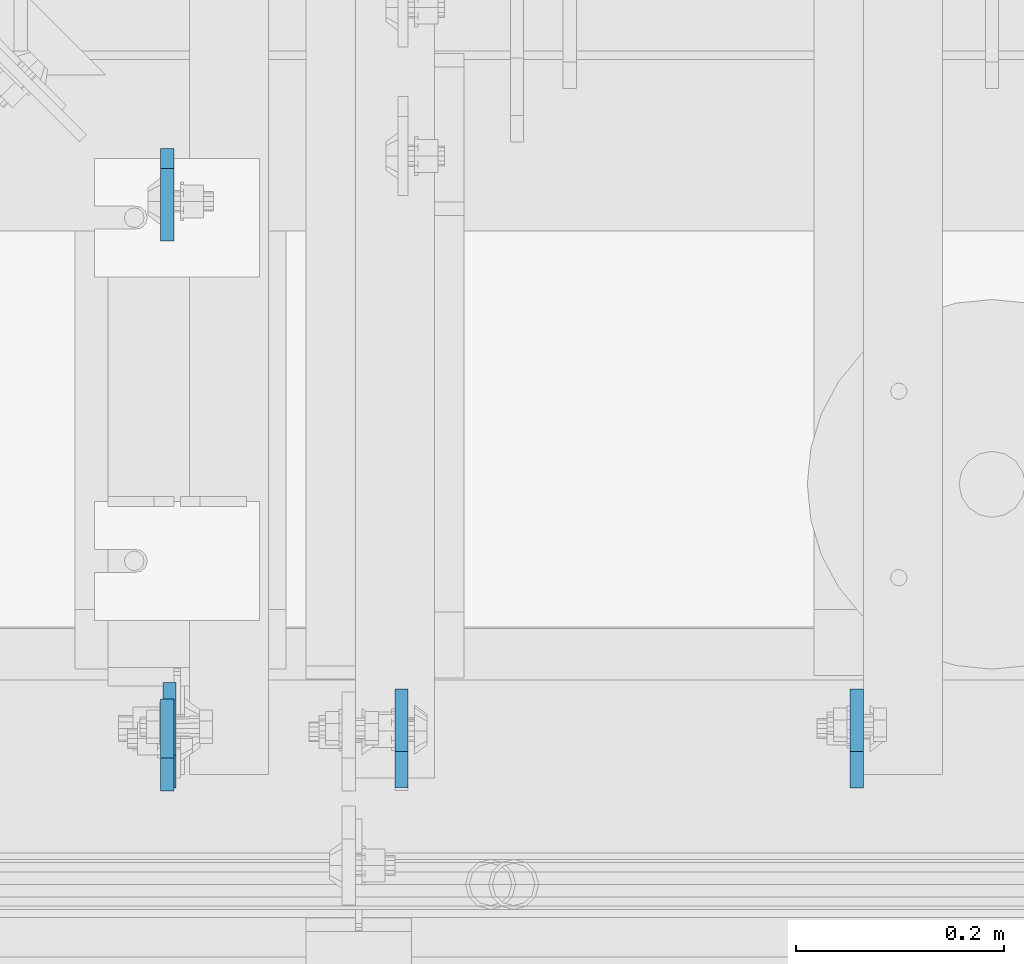
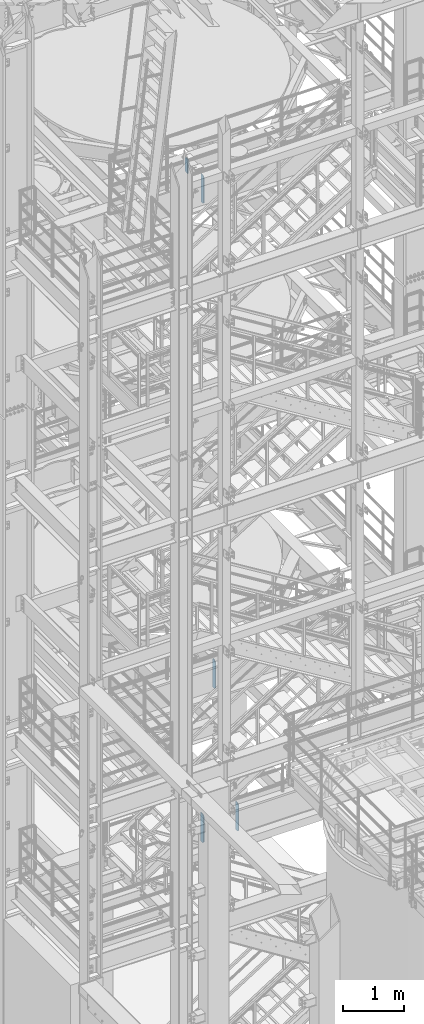
# One storey, part 1495 of 1876: 5 plates, 4 elements without a shape of their own.
"""IFC2X3 building model written with IfcOpenShell, lengths in millimetres."""

from ifc_helpers import new_model, si_unit, frame, origin_with_axes, place, context, subcontext, project, spatial, faceted_brep, material, type_object, element, aggregate, save


model = new_model("IFC2X3")

# Units and contexts
model_context = context("Model", 3, precision=1e-05, world=origin_with_axes())
body_context = subcontext(model_context, "Body", "Model", "MODEL_VIEW")
ifc_project = project(units=[si_unit("LENGTHUNIT", "METRE", prefix="MILLI"), si_unit("AREAUNIT", "SQUARE_METRE"), si_unit("VOLUMEUNIT", "CUBIC_METRE"), si_unit("MASSUNIT", "GRAM", prefix="KILO"), si_unit("TIMEUNIT", "SECOND"), si_unit("PLANEANGLEUNIT", "RADIAN"), si_unit("SOLIDANGLEUNIT", "STERADIAN"), si_unit("THERMODYNAMICTEMPERATUREUNIT", "DEGREE_CELSIUS"), si_unit("LUMINOUSINTENSITYUNIT", "LUMEN")], contexts=[model_context])

# Site, building, storey
site_placement = place(None, origin_with_axes())
site = spatial("IfcSite", under=ifc_project, at=site_placement, CompositionType="ELEMENT")
building_placement = place(site_placement, origin_with_axes())
building = spatial("IfcBuilding", under=site, at=building_placement, Name="Undefined", CompositionType="ELEMENT")
storey_placement = place(building_placement, origin_with_axes())
storey = spatial("IfcBuildingStorey", under=building, at=storey_placement, Name="Undefined", CompositionType="ELEMENT", Elevation=0.0)

# Assembly, plate
assembly_1_placement = place(storey_placement, origin_with_axes())
assembly_1 = element("IfcElementAssembly", 1, at=assembly_1_placement, inside=storey, Name="BEAM", AssemblyPlace="NOTDEFINED", PredefinedType="RIGID_FRAME")
ifc_material = material(Name="STEEL/A36")
plate_type_1 = type_object("IfcPlateType", PredefinedType="NOTDEFINED")
plate_1_placement = place(assembly_1_placement, frame((3625.84999990463, -4564.85625, 17386.3), z_axis=(0.0, 0.0, 1.0), x_axis=(0.0, 1.0, 0.0)))
plate_1 = element("IfcPlate", 2, at=plate_1_placement, type_object=plate_type_1, material=ifc_material, Name="PLATE", context=body_context, shape_type="Brep", body=[
    faceted_brep([(0.0, -6.34999999999991, 31.75), (0.0, -6.34999999999991, 539.75), (0.0, 6.34999999999991, 539.75), (0.0, 6.34999999999991, 31.75), (31.75, -6.34999999999991, 571.5), (31.75, 6.34999999999991, 571.5), (88.9000015258789, -6.34999999999991, 571.5), (88.9000015258789, 6.34999999999991, 571.5), (88.9000015258789, -6.34999999999991, 0.0), (88.9000015258789, 6.34999999999991, 0.0), (31.75, -6.34999999999991, 0.0), (31.75, 6.34999999999991, 0.0)], [[[0, 1, 2, 3]], [[1, 4, 5, 2]], [[4, 6, 7, 5]], [[6, 8, 9, 7]], [[8, 10, 11, 9]], [[10, 0, 3, 11]], [[5, 7, 9, 11, 3, 2]], [[10, 8, 6, 4, 1, 0]]]),
])
aggregate(assembly_1, [plate_1])

assembly_2_placement = place(storey_placement, origin_with_axes())
assembly_2 = element("IfcElementAssembly", 3, at=assembly_2_placement, inside=storey, Name="BEAM", AssemblyPlace="NOTDEFINED", PredefinedType="RIGID_FRAME")
plate_2_placement = place(assembly_2_placement, frame((3625.84999989042, -3946.525, 17681.575), z_axis=(0.0, 0.0, 1.0), x_axis=(0.0, -1.0, 0.0)))
plate_2 = element("IfcPlate", 4, at=plate_2_placement, type_object=plate_type_1, material=ifc_material, Name="PLATE", context=body_context, shape_type="Brep", body=[
    faceted_brep([(0.0, -6.35000000000196, 19.0499992370605), (0.0, -6.35000000000036, 271.462512969971), (0.0, 6.35000000000036, 271.462512969971), (0.0, 6.35000000000105, 19.0499992370605), (19.0499992370605, -6.35000000000036, 290.512512207031), (19.0499992370605, 6.35000000000036, 290.512512207031), (88.9000015258789, -6.35000000000036, 290.512512207031), (88.9000015258789, 6.35000000000036, 290.512512207031), (88.9000015258789, -6.34999999999991, 0.0), (88.9000015258789, 6.34999999999991, 0.0), (19.0499992370642, -6.35000000000105, 0.0), (19.0499992370633, 6.35000000000105, 0.0)], [[[0, 1, 2, 3]], [[1, 4, 5, 2]], [[4, 6, 7, 5]], [[6, 8, 9, 7]], [[8, 10, 11, 9]], [[10, 0, 3, 11]], [[5, 7, 9, 11, 3, 2]], [[10, 8, 6, 4, 1, 0]]]),
])
aggregate(assembly_2, [plate_2])

assembly_3_placement = place(storey_placement, origin_with_axes())
assembly_3 = element("IfcElementAssembly", 5, at=assembly_3_placement, inside=storey, Name="BEAM", AssemblyPlace="NOTDEFINED", PredefinedType="RIGID_FRAME")
plate_type_2 = type_object("IfcPlateType", PredefinedType="NOTDEFINED")
plate_3_placement = place(assembly_3_placement, frame((3851.27499990463, -4561.68125, 7543.8), z_axis=(0.0, 0.0, 1.0), x_axis=(0.0, 1.0, 0.0)))
plate_3 = element("IfcPlate", 6, at=plate_3_placement, type_object=plate_type_2, material=ifc_material, Name="PLATE", context=body_context, shape_type="Brep", body=[
    faceted_brep([(0.0, -6.34999999999991, 34.9249992370605), (0.0, -6.35000000000036, 538.162475585938), (0.0, 6.35000000000036, 538.162475585938), (0.0, 6.34999999999991, 34.9249992370605), (34.9249992370605, -6.34999999999991, 573.087524414062), (34.9249992370605, 6.34999999999991, 573.087524414062), (95.25, -6.34999999999991, 573.087524414062), (95.25, 6.34999999999991, 573.087524414062), (95.25, -6.35000000000036, 0.0), (95.25, 6.35000000000036, 0.0), (34.9249992370605, -6.34999999999991, 0.0), (34.9249992370605, 6.34999999999991, 0.0)], [[[0, 1, 2, 3]], [[1, 4, 5, 2]], [[4, 6, 7, 5]], [[6, 8, 9, 7]], [[8, 10, 11, 9]], [[10, 0, 3, 11]], [[5, 7, 9, 11, 3, 2]], [[10, 8, 6, 4, 1, 0]]]),
])
aggregate(assembly_3, [plate_3])

# Assembly, plates
assembly_4_placement = place(storey_placement, origin_with_axes())
assembly_4 = element("IfcElementAssembly", 7, at=assembly_4_placement, inside=storey, Name="BEAM", AssemblyPlace="NOTDEFINED", PredefinedType="RIGID_FRAME")
plate_4_placement = place(assembly_4_placement, frame((4289.42499990463, -4561.68125, 4521.2), z_axis=(0.0, 0.0, 1.0), x_axis=(0.0, 1.0, 0.0)))
plate_4 = element("IfcPlate", 8, at=plate_4_placement, type_object=plate_type_2, material=ifc_material, Name="PLATE", context=body_context, shape_type="Brep", body=[
    faceted_brep([(0.0, -6.34999999999991, 34.9249992370605), (0.0, -6.35000000000036, 538.162475585938), (0.0, 6.35000000000036, 538.162475585938), (0.0, 6.34999999999991, 34.9249992370605), (34.9249992370605, -6.34999999999991, 573.087524414062), (34.9249992370605, 6.34999999999991, 573.087524414062), (95.25, -6.34999999999991, 573.087524414062), (95.25, 6.34999999999991, 573.087524414062), (95.25, -6.35000000000036, 0.0), (95.25, 6.35000000000036, 0.0), (34.9249992370605, -6.34999999999991, 0.0), (34.9249992370605, 6.34999999999991, 0.0)], [[[0, 1, 2, 3]], [[1, 4, 5, 2]], [[4, 6, 7, 5]], [[6, 8, 9, 7]], [[8, 10, 11, 9]], [[10, 0, 3, 11]], [[5, 7, 9, 11, 3, 2]], [[10, 8, 6, 4, 1, 0]]]),
])
plate_type_3 = type_object("IfcPlateType", PredefinedType="NOTDEFINED")
plate_5_placement = place(assembly_4_placement, frame((3628.23124990463, -4561.68125, 4521.2), z_axis=(0.0, 0.0, 1.0), x_axis=(0.0, 1.0, 0.0)))
plate_5 = element("IfcPlate", 9, at=plate_5_placement, type_object=plate_type_3, material=ifc_material, Name="PLATE", context=body_context, shape_type="Brep", body=[
    faceted_brep([(0.0, -6.34999999999991, 31.75), (0.0, -6.35000000000036, 541.337524414062), (0.0, 6.35000000000036, 541.337524414062), (0.0, 6.34999999999991, 31.75), (31.75, -6.35000000000036, 573.087524414062), (31.75, 6.35000000000036, 573.087524414062), (101.599998474121, -6.35000000000036, 573.087524414062), (101.599998474121, 6.35000000000036, 573.087524414062), (101.599998474121, -6.35000000000036, 0.0), (101.599998474121, 6.35000000000036, 0.0), (31.75, -6.34999999999991, 0.0), (31.75, 6.34999999999991, 0.0)], [[[0, 1, 2, 3]], [[1, 4, 5, 2]], [[4, 6, 7, 5]], [[6, 8, 9, 7]], [[8, 10, 11, 9]], [[10, 0, 3, 11]], [[5, 7, 9, 11, 3, 2]], [[10, 8, 6, 4, 1, 0]]]),
])
aggregate(assembly_4, [plate_5, plate_4])

save(model, "model.ifc")
